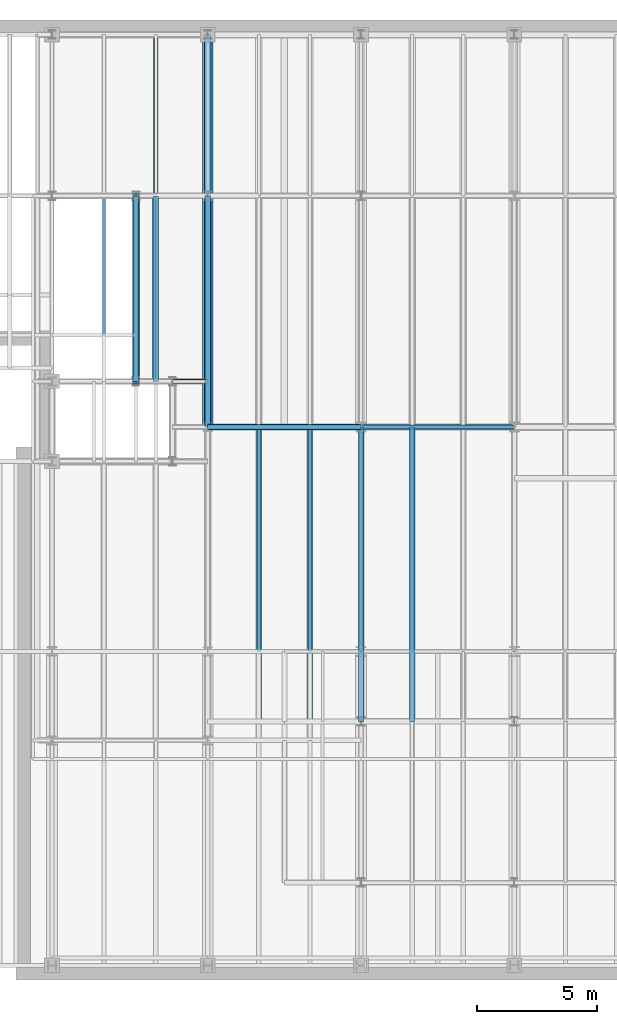
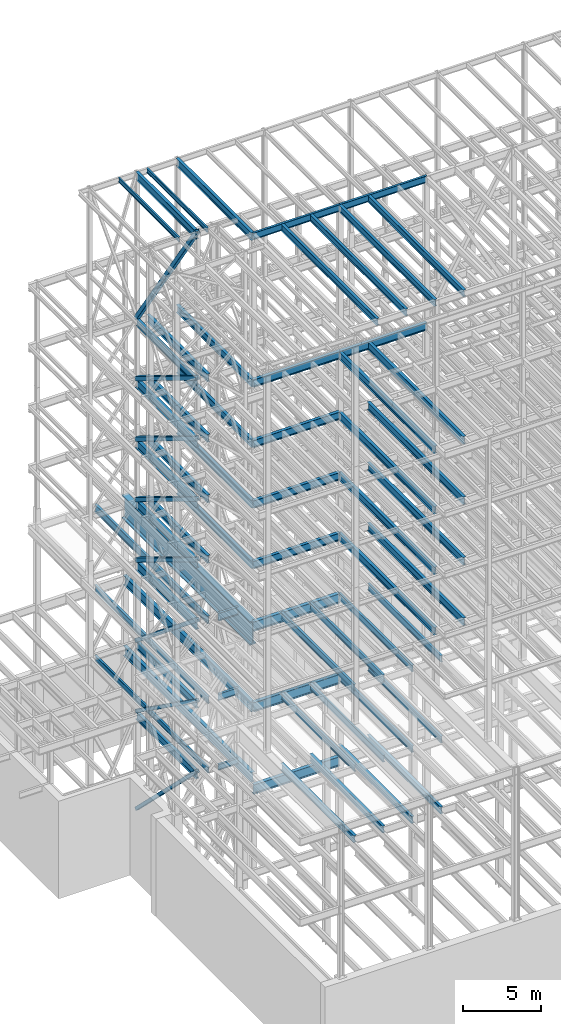
# One storey, part 127 of 150: 70 beams.
"""IFC2X3 building model written with IfcOpenShell, lengths in millimetres."""

from ifc_helpers import new_model, si_unit, frame, origin_with_axes, origin_2d_with_axis, place, context, subcontext, project, spatial, hollow_rectangle, i_section, extrude, material, type_object, element, save


model = new_model("IFC2X3")

# Units and contexts
model_context = context("Model", 3, precision=1e-05, world=origin_with_axes())
body_context = subcontext(model_context, "Body", "Model", "MODEL_VIEW")
ifc_project = project(units=[si_unit("LENGTHUNIT", "METRE", prefix="MILLI"), si_unit("AREAUNIT", "SQUARE_METRE"), si_unit("VOLUMEUNIT", "CUBIC_METRE"), si_unit("MASSUNIT", "GRAM", prefix="KILO"), si_unit("TIMEUNIT", "SECOND"), si_unit("PLANEANGLEUNIT", "RADIAN"), si_unit("SOLIDANGLEUNIT", "STERADIAN"), si_unit("THERMODYNAMICTEMPERATUREUNIT", "DEGREE_CELSIUS"), si_unit("LUMINOUSINTENSITYUNIT", "LUMEN")], contexts=[model_context])

# Site, building, storey
site_placement = place(None, origin_with_axes())
site = spatial("IfcSite", under=ifc_project, at=site_placement, CompositionType="ELEMENT")
building_placement = place(site_placement, origin_with_axes())
building = spatial("IfcBuilding", under=site, at=building_placement, Name="Undefined", CompositionType="ELEMENT")
storey_placement = place(building_placement, origin_with_axes())
storey = spatial("IfcBuildingStorey", under=building, at=storey_placement, Name="Undefined", CompositionType="ELEMENT", Elevation=0.0)

# Beams
ifc_material_1 = material(Name="STEEL/A992")
beam_type_1 = type_object("IfcBeamType", Name="W18X35", PredefinedType="NOTDEFINED")
beam_1_placement = place(storey_placement, frame((10312.39949708, 24384.0, 23548.975), z_axis=(0.0, 0.0, 1.0), x_axis=(1.0, 0.0, 0.0)))
element("IfcBeam", 1, at=beam_1_placement, inside=storey, type_object=beam_type_1, material=ifc_material_1, Name="BEAM", ObjectType="W18X35", context=body_context, shape_type="SweptSolid", body=[
    extrude(i_section(OverallWidth=152.4, OverallDepth=450.85, WebThickness=7.9375, FlangeThickness=10.795, FilletRadius=17.78, at=origin_2d_with_axis()), frame((1473.20050292, 0.0, 0.0), z_axis=(-1.0, 0.0, 0.0), x_axis=(0.0, -1.0, 0.0)), (0.0, 0.0, 1.0), 1473.20050292),
])
beam_2_placement = place(storey_placement, frame((9618.13333333333, 24384.0, 23548.975), z_axis=(0.0, 0.0, 1.0), x_axis=(0.0, 1.0, 0.0)))
element("IfcBeam", 2, at=beam_2_placement, inside=storey, type_object=beam_type_1, material=ifc_material_1, Name="BEAM", ObjectType="W18X35", context=body_context, shape_type="SweptSolid", body=[
    extrude(i_section(OverallWidth=152.4, OverallDepth=450.85, WebThickness=7.9375, FlangeThickness=10.795, FilletRadius=17.78, at=origin_2d_with_axis()), frame((14478.0, 0.0, 0.0), z_axis=(-1.0, 0.0, 0.0), x_axis=(0.0, -1.0, 0.0)), (0.0, 0.0, 1.0), 14478.0),
])
beam_type_2 = type_object("IfcBeamType", PredefinedType="NOTDEFINED")
beam_3_placement = place(storey_placement, frame((11785.6, 22479.0, 34671.0), z_axis=(0.0, 0.0, 1.0), x_axis=(0.0, 1.0, 0.0)))
element("IfcBeam", 3, at=beam_3_placement, inside=storey, type_object=beam_type_2, material=ifc_material_1, Name="BEAM", context=body_context, shape_type="SweptSolid", body=[
    extrude(i_section(OverallWidth=457.2, OverallDepth=1828.8, WebThickness=44.45, FlangeThickness=88.9, FilletRadius=31.115, at=origin_2d_with_axis()), frame((16383.0, 0.0, 0.0), z_axis=(-1.0, 0.0, 0.0), x_axis=(0.0, -1.0, 0.0)), (0.0, 0.0, 1.0), 16383.0),
])
ifc_material_2 = material()
beam_type_3 = type_object("IfcBeamType", Name="HSS12X12X5/8", PredefinedType="NOTDEFINED")
beam_4_placement = place(storey_placement, frame((8788.39896651299, 32131.0000000001, 29286.2), z_axis=(0.0, 0.630879840272755, 0.775880549529), x_axis=(0.0, -0.775880549529, 0.630879840272755)))
element("IfcBeam", 4, at=beam_4_placement, inside=storey, type_object=beam_type_3, material=ifc_material_2, Name="BEAM", ObjectType="HSS12X12X5/8", context=body_context, shape_type="SweptSolid", body=[
    extrude(hollow_rectangle(XDim=304.8, YDim=304.8, WallThickness=15.875, InnerFilletRadius=15.875, OuterFilletRadius=31.75, at=origin_2d_with_axis()), frame((9984.78490704744, 0.0, 8.9387583291435e-12), z_axis=(-1.0, 0.0, 0.0), x_axis=(0.0, -1.0, 0.0)), (0.0, 0.0, 1.0), 9984.78490704744),
])
beam_type_4 = type_object("IfcBeamType", Name="HSS12X12X3/8", PredefinedType="NOTDEFINED")
beam_5_placement = place(storey_placement, frame((8788.39896651299, 32131.0000000001, 54483.0), z_axis=(0.0, 0.827780944763595, 0.56105143033976), x_axis=(0.0, -0.561051430339763, 0.827780944763593)))
element("IfcBeam", 5, at=beam_5_placement, inside=storey, type_object=beam_type_4, material=ifc_material_2, Name="BEAM", ObjectType="HSS12X12X3/8", context=body_context, shape_type="SweptSolid", body=[
    extrude(hollow_rectangle(XDim=304.8, YDim=304.8, WallThickness=9.525, InnerFilletRadius=9.5249, OuterFilletRadius=19.0499, at=origin_2d_with_axis()), frame((13808.0014948042, 0.0, 0.0), z_axis=(-1.0, 0.0, 0.0), x_axis=(0.0, -1.0, 0.0)), (0.0, 0.0, 1.0), 13808.0014948042),
])
for number, where, z_axis, x_axis, name in (
    (6, (8788.39896651299, 32131.0000000001, 40309.8), (0.0, 0.520657137219164, 0.853765861031434), (0.0, -0.853765861031433, 0.520657137219164), "BEAM"),
    (7, (8788.39896651299, 32131.0000000001, 35585.4), (0.0, 0.520657137219164, 0.853765861031434), (0.0, -0.853765861031433, 0.520657137219164), "BEAM"),
):
    element("IfcBeam", number, at=place(storey_placement, frame(where, z_axis=z_axis, x_axis=x_axis)), inside=storey, type_object=beam_type_4, material=ifc_material_2, Name=name, ObjectType="HSS12X12X3/8", context=body_context, shape_type="SweptSolid", body=[
        extrude(hollow_rectangle(XDim=304.8, YDim=304.8, WallThickness=9.525, InnerFilletRadius=9.5249, OuterFilletRadius=19.0499, at=origin_2d_with_axis()), frame((9073.91670448887, 0.0, 0.0), z_axis=(-1.0, 0.0, 0.0), x_axis=(0.0, -1.0, 0.0)), (0.0, 0.0, 1.0), 9073.91670448887),
    ])
beam_type_5 = type_object("IfcBeamType", Name="HSS10X10X1/2", PredefinedType="NOTDEFINED")
beam_6_placement = place(storey_placement, frame((8788.39896651299, 32131.0000000001, 23774.4), z_axis=(0.0, 0.579720908961089, 0.814815112595078), x_axis=(0.0, -0.814815112595078, 0.579720908961088)))
element("IfcBeam", 8, at=beam_6_placement, inside=storey, type_object=beam_type_5, material=ifc_material_2, Name="BEAM", ObjectType="HSS10X10X1/2", context=body_context, shape_type="SweptSolid", body=[
    extrude(hollow_rectangle(XDim=254.0, YDim=254.0, WallThickness=12.7, InnerFilletRadius=12.6999, OuterFilletRadius=25.3999, at=origin_2d_with_axis()), frame((9507.67838328591, 0.0, -5.27782172592745e-13), z_axis=(-1.0, 0.0, 0.0), x_axis=(0.0, -1.0, 0.0)), (0.0, 0.0, 1.0), 9507.67838328591),
])
beam_7_placement = place(storey_placement, frame((8788.39896651299, 32131.0000000001, 16154.4), z_axis=(0.0, 0.701238983615864, 0.71292628500946), x_axis=(0.0, -0.71292628500946, 0.701238983615864)))
element("IfcBeam", 9, at=beam_7_placement, inside=storey, type_object=beam_type_5, material=ifc_material_2, Name="BEAM", ObjectType="HSS10X10X1/2", context=body_context, shape_type="SweptSolid", body=[
    extrude(hollow_rectangle(XDim=254.0, YDim=254.0, WallThickness=12.7, InnerFilletRadius=12.6999, OuterFilletRadius=25.3999, at=origin_2d_with_axis()), frame((10866.4809851213, 0.0, -6.03210869316655e-13), z_axis=(-1.0, 0.0, 0.0), x_axis=(0.0, -1.0, 0.0)), (0.0, 0.0, 1.0), 10866.4809851213),
])
beam_type_6 = type_object("IfcBeamType", Name="HSS12X12X1/4", PredefinedType="NOTDEFINED")
beam_8_placement = place(storey_placement, frame((8788.39896651299, 32131.0000000001, 49758.6), z_axis=(0.0, 0.520657137219164, 0.853765861031434), x_axis=(0.0, -0.853765861031433, 0.520657137219164)))
element("IfcBeam", 10, at=beam_8_placement, inside=storey, type_object=beam_type_6, material=ifc_material_2, Name="BEAM", ObjectType="HSS12X12X1/4", context=body_context, shape_type="SweptSolid", body=[
    extrude(hollow_rectangle(XDim=304.8, YDim=304.8, WallThickness=6.35, InnerFilletRadius=6.3499, OuterFilletRadius=12.6999, at=origin_2d_with_axis()), frame((9073.91670448887, 0.0, 0.0), z_axis=(-1.0, 0.0, 0.0), x_axis=(0.0, -1.0, 0.0)), (0.0, 0.0, 1.0), 9073.91670448887),
])
beam_type_7 = type_object("IfcBeamType", Name="HSS12X12X5/16", PredefinedType="NOTDEFINED")
beam_9_placement = place(storey_placement, frame((8788.39896651299, 32131.0000000001, 45034.2), z_axis=(0.0, 0.520657137219164, 0.853765861031434), x_axis=(0.0, -0.853765861031433, 0.520657137219164)))
element("IfcBeam", 11, at=beam_9_placement, inside=storey, type_object=beam_type_7, material=ifc_material_2, Name="BEAM", ObjectType="HSS12X12X5/16", context=body_context, shape_type="SweptSolid", body=[
    extrude(hollow_rectangle(XDim=304.8, YDim=304.8, WallThickness=7.9375, InnerFilletRadius=7.9375, OuterFilletRadius=15.875, at=origin_2d_with_axis()), frame((9073.91670448887, 0.0, 0.0), z_axis=(-1.0, 0.0, 0.0), x_axis=(0.0, -1.0, 0.0)), (0.0, 0.0, 1.0), 9073.91670448888),
])
beam_type_8 = type_object("IfcBeamType", Name="W21X50", PredefinedType="NOTDEFINED")
for number, where, z_axis, x_axis, name in (
    (12, (18186.4, 22479.0, 65647.8875), (0.0, 0.0, 1.0), (1.0, 0.0, 0.0), "BEAM"),
    (13, (11785.6, 22479.0, 65647.8875), (0.0, 0.0, 1.0), (1.0, 0.0, 0.0), "BEAM"),
):
    element("IfcBeam", number, at=place(storey_placement, frame(where, z_axis=z_axis, x_axis=x_axis)), inside=storey, type_object=beam_type_8, material=ifc_material_1, Name=name, ObjectType="W21X50", context=body_context, shape_type="SweptSolid", body=[
        extrude(i_section(OverallWidth=165.862, OverallDepth=530.225, WebThickness=9.5249, FlangeThickness=13.589, FilletRadius=18.1609, at=origin_2d_with_axis()), frame((6400.80000000001, 0.0, 0.0), z_axis=(-1.0, 0.0, 0.0), x_axis=(0.0, -1.0, 0.0)), (0.0, 0.0, 1.0), 6400.8),
    ])
beam_type_9 = type_object("IfcBeamType", Name="W24X68", PredefinedType="NOTDEFINED")
beam_10_placement = place(storey_placement, frame((11785.6, 22479.0, 65611.375), z_axis=(0.0, 0.0, 1.0), x_axis=(0.0, 1.0, 0.0)))
element("IfcBeam", 14, at=beam_10_placement, inside=storey, type_object=beam_type_9, material=ifc_material_1, Name="BEAM", ObjectType="W24X68", context=body_context, shape_type="SweptSolid", body=[
    extrude(i_section(OverallWidth=227.838, OverallDepth=603.25, WebThickness=11.1125, FlangeThickness=14.859, FilletRadius=23.2409, at=origin_2d_with_axis()), frame((9652.0, 0.0, 0.0), z_axis=(-1.0, 0.0, 0.0), x_axis=(0.0, -1.0, 0.0)), (0.0, 0.0, 1.0), 9652.0),
])
beam_11_placement = place(storey_placement, frame((18186.4, 22479.0, 54181.375), z_axis=(0.0, 0.0, 1.0), x_axis=(1.0, 0.0, 0.0)))
element("IfcBeam", 15, at=beam_11_placement, inside=storey, type_object=beam_type_9, material=ifc_material_1, Name="BEAM", ObjectType="W24X68", context=body_context, shape_type="SweptSolid", body=[
    extrude(i_section(OverallWidth=227.838, OverallDepth=603.25, WebThickness=11.1125, FlangeThickness=14.859, FilletRadius=23.2409, at=origin_2d_with_axis()), frame((6400.80000000001, 0.0, 0.0), z_axis=(-1.0, 0.0, 0.0), x_axis=(0.0, -1.0, 0.0)), (0.0, 0.0, 1.0), 6400.8),
])
beam_12_placement = place(storey_placement, frame((11785.6, 22479.0, 54181.375), z_axis=(0.0, 0.0, 1.0), x_axis=(0.0, 1.0, 0.0)))
element("IfcBeam", 16, at=beam_12_placement, inside=storey, type_object=beam_type_9, material=ifc_material_1, Name="BEAM", ObjectType="W24X68", context=body_context, shape_type="SweptSolid", body=[
    extrude(i_section(OverallWidth=227.838, OverallDepth=603.25, WebThickness=11.1125, FlangeThickness=14.859, FilletRadius=23.2409, at=origin_2d_with_axis()), frame((9652.0, 0.0, 0.0), z_axis=(-1.0, 0.0, 0.0), x_axis=(0.0, -1.0, 0.0)), (0.0, 0.0, 1.0), 9652.0),
])
beam_13_placement = place(storey_placement, frame((9618.13333333333, 24384.0, 54181.375), z_axis=(0.0, 0.0, 1.0), x_axis=(0.0, 1.0, 0.0)))
element("IfcBeam", 17, at=beam_13_placement, inside=storey, type_object=beam_type_9, material=ifc_material_1, Name="BEAM", ObjectType="W24X68", context=body_context, shape_type="SweptSolid", body=[
    extrude(i_section(OverallWidth=227.838, OverallDepth=603.25, WebThickness=11.1125, FlangeThickness=14.859, FilletRadius=23.2409, at=origin_2d_with_axis()), frame((7747.0, 0.0, 0.0), z_axis=(-1.0, 0.0, 0.0), x_axis=(0.0, -1.0, 0.0)), (0.0, 0.0, 1.0), 7747.0),
])
beam_14_placement = place(storey_placement, frame((11785.6, 22479.0, 54181.375), z_axis=(0.0, 0.0, 1.0), x_axis=(1.0, 0.0, 0.0)))
element("IfcBeam", 18, at=beam_14_placement, inside=storey, type_object=beam_type_9, material=ifc_material_1, Name="BEAM", ObjectType="W24X68", context=body_context, shape_type="SweptSolid", body=[
    extrude(i_section(OverallWidth=227.838, OverallDepth=603.25, WebThickness=11.1125, FlangeThickness=14.859, FilletRadius=23.2409, at=origin_2d_with_axis()), frame((6400.80000000001, 0.0, 0.0), z_axis=(-1.0, 0.0, 0.0), x_axis=(0.0, -1.0, 0.0)), (0.0, 0.0, 1.0), 6400.8),
])
for number, where, z_axis, x_axis, name in (
    (19, (20320.0, 10185.4, 54181.375), (0.0, 0.0, 1.0), (0.0, 1.0, 0.0), "BEAM"),
    (20, (18186.4, 10185.4, 54181.375), (0.0, 0.0, 1.0), (0.0, 1.0, 0.0), "BEAM"),
):
    element("IfcBeam", number, at=place(storey_placement, frame(where, z_axis=z_axis, x_axis=x_axis)), inside=storey, type_object=beam_type_9, material=ifc_material_1, Name=name, ObjectType="W24X68", context=body_context, shape_type="SweptSolid", body=[
        extrude(i_section(OverallWidth=227.838, OverallDepth=603.25, WebThickness=11.1125, FlangeThickness=14.859, FilletRadius=23.2409, at=origin_2d_with_axis()), frame((12293.6, 0.0, 0.0), z_axis=(-1.0, 0.0, 0.0), x_axis=(0.0, -1.0, 0.0)), (0.0, 0.0, 1.0), 12293.6),
    ])
beam_15_placement = place(storey_placement, frame((11785.6, 22479.0, 49456.975), z_axis=(0.0, 0.0, 1.0), x_axis=(0.0, 1.0, 0.0)))
element("IfcBeam", 21, at=beam_15_placement, inside=storey, type_object=beam_type_9, material=ifc_material_1, Name="BEAM", ObjectType="W24X68", context=body_context, shape_type="SweptSolid", body=[
    extrude(i_section(OverallWidth=227.838, OverallDepth=603.25, WebThickness=11.1125, FlangeThickness=14.859, FilletRadius=23.2409, at=origin_2d_with_axis()), frame((9652.0, 0.0, 0.0), z_axis=(-1.0, 0.0, 0.0), x_axis=(0.0, -1.0, 0.0)), (0.0, 0.0, 1.0), 9652.0),
])
beam_16_placement = place(storey_placement, frame((9618.13333333333, 24384.0, 49456.975), z_axis=(0.0, 0.0, 1.0), x_axis=(0.0, 1.0, 0.0)))
element("IfcBeam", 22, at=beam_16_placement, inside=storey, type_object=beam_type_9, material=ifc_material_1, Name="BEAM", ObjectType="W24X68", context=body_context, shape_type="SweptSolid", body=[
    extrude(i_section(OverallWidth=227.838, OverallDepth=603.25, WebThickness=11.1125, FlangeThickness=14.859, FilletRadius=23.2409, at=origin_2d_with_axis()), frame((7747.0, 0.0, 0.0), z_axis=(-1.0, 0.0, 0.0), x_axis=(0.0, -1.0, 0.0)), (0.0, 0.0, 1.0), 7747.0),
])
beam_17_placement = place(storey_placement, frame((11785.6, 22479.0, 49456.975), z_axis=(0.0, 0.0, 1.0), x_axis=(1.0, 0.0, 0.0)))
element("IfcBeam", 23, at=beam_17_placement, inside=storey, type_object=beam_type_9, material=ifc_material_1, Name="BEAM", ObjectType="W24X68", context=body_context, shape_type="SweptSolid", body=[
    extrude(i_section(OverallWidth=227.838, OverallDepth=603.25, WebThickness=11.1125, FlangeThickness=14.859, FilletRadius=23.2409, at=origin_2d_with_axis()), frame((6400.80000000001, 0.0, 0.0), z_axis=(-1.0, 0.0, 0.0), x_axis=(0.0, -1.0, 0.0)), (0.0, 0.0, 1.0), 6400.8),
])
for number, where, z_axis, x_axis, name in (
    (24, (20320.0, 10185.4, 49456.975), (0.0, 0.0, 1.0), (0.0, 1.0, 0.0), "BEAM"),
    (25, (18186.4, 10185.4, 49456.975), (0.0, 0.0, 1.0), (0.0, 1.0, 0.0), "BEAM"),
):
    element("IfcBeam", number, at=place(storey_placement, frame(where, z_axis=z_axis, x_axis=x_axis)), inside=storey, type_object=beam_type_9, material=ifc_material_1, Name=name, ObjectType="W24X68", context=body_context, shape_type="SweptSolid", body=[
        extrude(i_section(OverallWidth=227.838, OverallDepth=603.25, WebThickness=11.1125, FlangeThickness=14.859, FilletRadius=23.2409, at=origin_2d_with_axis()), frame((12293.6, 0.0, 0.0), z_axis=(-1.0, 0.0, 0.0), x_axis=(0.0, -1.0, 0.0)), (0.0, 0.0, 1.0), 12293.6),
    ])
beam_18_placement = place(storey_placement, frame((11785.6, 22479.0, 44732.575), z_axis=(0.0, 0.0, 1.0), x_axis=(0.0, 1.0, 0.0)))
element("IfcBeam", 26, at=beam_18_placement, inside=storey, type_object=beam_type_9, material=ifc_material_1, Name="BEAM", ObjectType="W24X68", context=body_context, shape_type="SweptSolid", body=[
    extrude(i_section(OverallWidth=227.838, OverallDepth=603.25, WebThickness=11.1125, FlangeThickness=14.859, FilletRadius=23.2409, at=origin_2d_with_axis()), frame((9652.0, 0.0, 0.0), z_axis=(-1.0, 0.0, 0.0), x_axis=(0.0, -1.0, 0.0)), (0.0, 0.0, 1.0), 9652.0),
])
beam_19_placement = place(storey_placement, frame((9618.13333333333, 24384.0, 44732.575), z_axis=(0.0, 0.0, 1.0), x_axis=(0.0, 1.0, 0.0)))
element("IfcBeam", 27, at=beam_19_placement, inside=storey, type_object=beam_type_9, material=ifc_material_1, Name="BEAM", ObjectType="W24X68", context=body_context, shape_type="SweptSolid", body=[
    extrude(i_section(OverallWidth=227.838, OverallDepth=603.25, WebThickness=11.1125, FlangeThickness=14.859, FilletRadius=23.2409, at=origin_2d_with_axis()), frame((7747.0, 0.0, 0.0), z_axis=(-1.0, 0.0, 0.0), x_axis=(0.0, -1.0, 0.0)), (0.0, 0.0, 1.0), 7747.0),
])
beam_20_placement = place(storey_placement, frame((11785.6, 22479.0, 44732.575), z_axis=(0.0, 0.0, 1.0), x_axis=(1.0, 0.0, 0.0)))
element("IfcBeam", 28, at=beam_20_placement, inside=storey, type_object=beam_type_9, material=ifc_material_1, Name="BEAM", ObjectType="W24X68", context=body_context, shape_type="SweptSolid", body=[
    extrude(i_section(OverallWidth=227.838, OverallDepth=603.25, WebThickness=11.1125, FlangeThickness=14.859, FilletRadius=23.2409, at=origin_2d_with_axis()), frame((6400.80000000001, 0.0, 0.0), z_axis=(-1.0, 0.0, 0.0), x_axis=(0.0, -1.0, 0.0)), (0.0, 0.0, 1.0), 6400.8),
])
for number, where, z_axis, x_axis, name in (
    (29, (20320.0, 10185.4, 44732.575), (0.0, 0.0, 1.0), (0.0, 1.0, 0.0), "BEAM"),
    (30, (18186.4, 10185.4, 44732.575), (0.0, 0.0, 1.0), (0.0, 1.0, 0.0), "BEAM"),
):
    element("IfcBeam", number, at=place(storey_placement, frame(where, z_axis=z_axis, x_axis=x_axis)), inside=storey, type_object=beam_type_9, material=ifc_material_1, Name=name, ObjectType="W24X68", context=body_context, shape_type="SweptSolid", body=[
        extrude(i_section(OverallWidth=227.838, OverallDepth=603.25, WebThickness=11.1125, FlangeThickness=14.859, FilletRadius=23.2409, at=origin_2d_with_axis()), frame((12293.6, 0.0, 0.0), z_axis=(-1.0, 0.0, 0.0), x_axis=(0.0, -1.0, 0.0)), (0.0, 0.0, 1.0), 12293.6),
    ])
beam_21_placement = place(storey_placement, frame((11785.6, 22479.0, 40008.175), z_axis=(0.0, 0.0, 1.0), x_axis=(0.0, 1.0, 0.0)))
element("IfcBeam", 31, at=beam_21_placement, inside=storey, type_object=beam_type_9, material=ifc_material_1, Name="BEAM", ObjectType="W24X68", context=body_context, shape_type="SweptSolid", body=[
    extrude(i_section(OverallWidth=227.838, OverallDepth=603.25, WebThickness=11.1125, FlangeThickness=14.859, FilletRadius=23.2409, at=origin_2d_with_axis()), frame((9652.0, 0.0, 0.0), z_axis=(-1.0, 0.0, 0.0), x_axis=(0.0, -1.0, 0.0)), (0.0, 0.0, 1.0), 9652.0),
])
beam_22_placement = place(storey_placement, frame((9618.13333333333, 24384.0, 40008.175), z_axis=(0.0, 0.0, 1.0), x_axis=(0.0, 1.0, 0.0)))
element("IfcBeam", 32, at=beam_22_placement, inside=storey, type_object=beam_type_9, material=ifc_material_1, Name="BEAM", ObjectType="W24X68", context=body_context, shape_type="SweptSolid", body=[
    extrude(i_section(OverallWidth=227.838, OverallDepth=603.25, WebThickness=11.1125, FlangeThickness=14.859, FilletRadius=23.2409, at=origin_2d_with_axis()), frame((7747.0, 0.0, 0.0), z_axis=(-1.0, 0.0, 0.0), x_axis=(0.0, -1.0, 0.0)), (0.0, 0.0, 1.0), 7747.0),
])
beam_23_placement = place(storey_placement, frame((11785.6, 22479.0, 40008.175), z_axis=(0.0, 0.0, 1.0), x_axis=(1.0, 0.0, 0.0)))
element("IfcBeam", 33, at=beam_23_placement, inside=storey, type_object=beam_type_9, material=ifc_material_1, Name="BEAM", ObjectType="W24X68", context=body_context, shape_type="SweptSolid", body=[
    extrude(i_section(OverallWidth=227.838, OverallDepth=603.25, WebThickness=11.1125, FlangeThickness=14.859, FilletRadius=23.2409, at=origin_2d_with_axis()), frame((6400.80000000001, 0.0, 0.0), z_axis=(-1.0, 0.0, 0.0), x_axis=(0.0, -1.0, 0.0)), (0.0, 0.0, 1.0), 6400.8),
])
for number, where, z_axis, x_axis, name in (
    (34, (20320.0, 10185.4, 40008.175), (0.0, 0.0, 1.0), (0.0, 1.0, 0.0), "BEAM"),
    (35, (18186.4, 10185.4, 40008.175), (0.0, 0.0, 1.0), (0.0, 1.0, 0.0), "BEAM"),
):
    element("IfcBeam", number, at=place(storey_placement, frame(where, z_axis=z_axis, x_axis=x_axis)), inside=storey, type_object=beam_type_9, material=ifc_material_1, Name=name, ObjectType="W24X68", context=body_context, shape_type="SweptSolid", body=[
        extrude(i_section(OverallWidth=227.838, OverallDepth=603.25, WebThickness=11.1125, FlangeThickness=14.859, FilletRadius=23.2409, at=origin_2d_with_axis()), frame((12293.6, 0.0, 0.0), z_axis=(-1.0, 0.0, 0.0), x_axis=(0.0, -1.0, 0.0)), (0.0, 0.0, 1.0), 12293.6),
    ])
beam_24_placement = place(storey_placement, frame((8788.39949708, 24384.0, 28984.575), z_axis=(0.0, 0.0, 1.0), x_axis=(0.0, 1.0, 0.0)))
element("IfcBeam", 36, at=beam_24_placement, inside=storey, type_object=beam_type_9, material=ifc_material_1, Name="BEAM", ObjectType="W24X68", context=body_context, shape_type="SweptSolid", body=[
    extrude(i_section(OverallWidth=227.838, OverallDepth=603.25, WebThickness=11.1125, FlangeThickness=14.859, FilletRadius=23.2409, at=origin_2d_with_axis()), frame((7746.99929895383, 0.0, 0.0), z_axis=(-1.0, 0.0, 0.0), x_axis=(0.0, -1.0, 0.0)), (0.0, 0.0, 1.0), 7746.99929895383),
])
beam_type_10 = type_object("IfcBeamType", Name="W14X22", PredefinedType="NOTDEFINED")
for number, where, z_axis, x_axis, name in (
    (37, (9550.39949708, 24384.0, 65738.375), (0.0, 0.0, 1.0), (0.0, 1.0, 0.0), "BEAM"),
    (38, (7450.66666666667, 24384.0, 65738.375), (0.0, 0.0, 1.0), (0.0, 1.0, 0.0), "BEAM"),
):
    element("IfcBeam", number, at=place(storey_placement, frame(where, z_axis=z_axis, x_axis=x_axis)), inside=storey, type_object=beam_type_10, material=ifc_material_1, Name=name, ObjectType="W14X22", context=body_context, shape_type="SweptSolid", body=[
        extrude(i_section(OverallWidth=127.0, OverallDepth=349.25, WebThickness=6.3499, FlangeThickness=8.509, FilletRadius=18.4785, at=origin_2d_with_axis()), frame((7746.99845060008, 0.0, 0.0), z_axis=(-1.0, 0.0, 0.0), x_axis=(0.0, -1.0, 0.0)), (0.0, 0.0, 1.0), 7746.99845060008),
    ])
beam_type_11 = type_object("IfcBeamType", Name="W21X55", PredefinedType="NOTDEFINED")
for number, where, z_axis, x_axis, name in (
    (39, (16052.8, 10185.4, 65649.475), (0.0, 0.0, 1.0), (0.0, 1.0, 0.0), "BEAM"),
    (40, (13919.2, 10185.4, 65649.475), (0.0, 0.0, 1.0), (0.0, 1.0, 0.0), "BEAM"),
    (41, (20320.0, 10185.4, 65649.475), (0.0, 0.0, 1.0), (0.0, 1.0, 0.0), "BEAM"),
    (42, (18186.4, 10185.4, 65649.475), (0.0, 0.0, 1.0), (0.0, 1.0, 0.0), "BEAM"),
):
    element("IfcBeam", number, at=place(storey_placement, frame(where, z_axis=z_axis, x_axis=x_axis)), inside=storey, type_object=beam_type_11, material=ifc_material_1, Name=name, ObjectType="W21X55", context=body_context, shape_type="SweptSolid", body=[
        extrude(i_section(OverallWidth=208.788, OverallDepth=527.05, WebThickness=9.5, FlangeThickness=13.2588, FilletRadius=16.8624, at=origin_2d_with_axis()), frame((12293.6, 0.0, 0.0), z_axis=(-1.0, 0.0, 0.0), x_axis=(0.0, -1.0, 0.0)), (0.0, 0.0, 1.0), 12293.6),
    ])
beam_type_12 = type_object("IfcBeamType", Name="W27X84", PredefinedType="NOTDEFINED")
for number, where, z_axis, x_axis, name in (
    (43, (8788.39949708, 24384.0, 49418.875), (0.0, 0.0, 1.0), (0.0, 1.0, 0.0), "BEAM"),
    (44, (8788.39949708, 24384.0, 44694.475), (0.0, 0.0, 1.0), (0.0, 1.0, 0.0), "BEAM"),
    (45, (8788.39949708, 24384.0, 39970.075), (0.0, 0.0, 1.0), (0.0, 1.0, 0.0), "BEAM"),
):
    element("IfcBeam", number, at=place(storey_placement, frame(where, z_axis=z_axis, x_axis=x_axis)), inside=storey, type_object=beam_type_12, material=ifc_material_1, Name=name, ObjectType="W27X84", context=body_context, shape_type="SweptSolid", body=[
        extrude(i_section(OverallWidth=254.0, OverallDepth=679.45, WebThickness=11.1125, FlangeThickness=16.256, FilletRadius=23.4314, at=origin_2d_with_axis()), frame((7747.0, 0.0, 0.0), z_axis=(-1.0, 0.0, 0.0), x_axis=(0.0, -1.0, 0.0)), (0.0, 0.0, 1.0), 7747.0),
    ])
beam_type_13 = type_object("IfcBeamType", Name="W24X76", PredefinedType="NOTDEFINED")
beam_25_placement = place(storey_placement, frame((8788.39949708, 24384.0, 65609.7875), z_axis=(0.0, 0.0, 1.0), x_axis=(0.0, 1.0, 0.0)))
element("IfcBeam", 46, at=beam_25_placement, inside=storey, type_object=beam_type_13, material=ifc_material_1, Name="BEAM", ObjectType="W24X76", context=body_context, shape_type="SweptSolid", body=[
    extrude(i_section(OverallWidth=228.346, OverallDepth=606.425, WebThickness=11.1125, FlangeThickness=17.272, FilletRadius=22.4155, at=origin_2d_with_axis()), frame((7746.99929895383, 0.0, 0.0), z_axis=(-1.0, 0.0, 0.0), x_axis=(0.0, -1.0, 0.0)), (0.0, 0.0, 1.0), 7746.99929895383),
])
beam_26_placement = place(storey_placement, frame((8788.39949708, 24384.0, 23471.1875), z_axis=(0.0, 0.0, 1.0), x_axis=(0.0, 1.0, 0.0)))
element("IfcBeam", 47, at=beam_26_placement, inside=storey, type_object=beam_type_13, material=ifc_material_1, Name="BEAM", ObjectType="W24X76", context=body_context, shape_type="SweptSolid", body=[
    extrude(i_section(OverallWidth=228.346, OverallDepth=606.425, WebThickness=11.1125, FlangeThickness=17.272, FilletRadius=22.4155, at=origin_2d_with_axis()), frame((7746.9992253, 0.0, 0.0), z_axis=(-1.0, 0.0, 0.0), x_axis=(0.0, -1.0, 0.0)), (0.0, 0.0, 1.0), 7746.9992253),
])
beam_type_14 = type_object("IfcBeamType", Name="W24X55", PredefinedType="NOTDEFINED")
beam_27_placement = place(storey_placement, frame((8788.39949708, 24384.0, 54182.9625), z_axis=(0.0, 0.0, 1.0), x_axis=(0.0, 1.0, 0.0)))
element("IfcBeam", 48, at=beam_27_placement, inside=storey, type_object=beam_type_14, material=ifc_material_1, Name="BEAM", ObjectType="W24X55", context=body_context, shape_type="SweptSolid", body=[
    extrude(i_section(OverallWidth=178.054, OverallDepth=600.075, WebThickness=9.5249, FlangeThickness=12.827, FilletRadius=23.6854, at=origin_2d_with_axis()), frame((7747.0, 0.0, 0.0), z_axis=(-1.0, 0.0, 0.0), x_axis=(0.0, -1.0, 0.0)), (0.0, 0.0, 1.0), 7747.0),
])
beam_type_15 = type_object("IfcBeamType", Name="W21X44", PredefinedType="NOTDEFINED")
for number, where, z_axis, x_axis, name in (
    (49, (13919.2, 13106.4, 35323.4625), (0.0, 0.0, 1.0), (0.0, 1.0, 0.0), "BEAM"),
    (50, (16052.8, 13106.4, 35323.4625), (0.0, 0.0, 1.0), (0.0, 1.0, 0.0), "BEAM"),
    (51, (18186.4, 13106.4, 35323.4625), (0.0, 0.0, 1.0), (0.0, 1.0, 0.0), "BEAM"),
    (52, (20320.0, 13106.4, 35323.4625), (0.0, 0.0, 1.0), (0.0, 1.0, 0.0), "BEAM"),
):
    element("IfcBeam", number, at=place(storey_placement, frame(where, z_axis=z_axis, x_axis=x_axis)), inside=storey, type_object=beam_type_15, material=ifc_material_1, Name=name, ObjectType="W21X44", context=body_context, shape_type="SweptSolid", body=[
        extrude(i_section(OverallWidth=165.1, OverallDepth=523.875, WebThickness=9.5249, FlangeThickness=11.43, FilletRadius=17.145, at=origin_2d_with_axis()), frame((9372.6, 0.0, 0.0), z_axis=(-1.0, 0.0, 0.0), x_axis=(0.0, -1.0, 0.0)), (0.0, 0.0, 1.0), 9372.6),
    ])
beam_28_placement = place(storey_placement, frame((9618.13289984, 24384.0, 29024.2625), z_axis=(0.0, 0.0, 1.0), x_axis=(0.0, 1.0, 0.0)))
element("IfcBeam", 53, at=beam_28_placement, inside=storey, type_object=beam_type_15, material=ifc_material_1, Name="BEAM", ObjectType="W21X44", context=body_context, shape_type="SweptSolid", body=[
    extrude(i_section(OverallWidth=165.1, OverallDepth=523.875, WebThickness=9.5249, FlangeThickness=11.43, FilletRadius=17.145, at=origin_2d_with_axis()), frame((14478.0, 0.0, 0.0), z_axis=(-1.0, 0.0, 0.0), x_axis=(0.0, -1.0, 0.0)), (0.0, 0.0, 1.0), 14478.0),
])
beam_29_placement = place(storey_placement, frame((10312.39949708, 24384.0, 29024.2625), z_axis=(0.0, 0.0, 1.0), x_axis=(1.0, 0.0, 0.0)))
element("IfcBeam", 54, at=beam_29_placement, inside=storey, type_object=beam_type_15, material=ifc_material_1, Name="BEAM", ObjectType="W21X44", context=body_context, shape_type="SweptSolid", body=[
    extrude(i_section(OverallWidth=165.1, OverallDepth=523.875, WebThickness=9.5249, FlangeThickness=11.43, FilletRadius=17.145, at=origin_2d_with_axis()), frame((1473.20050292, 0.0, 0.0), z_axis=(-1.0, 0.0, 0.0), x_axis=(0.0, -1.0, 0.0)), (0.0, 0.0, 1.0), 1473.20050292),
])
for number, where, z_axis, x_axis, name in (
    (55, (20320.0, 13106.4, 29024.2625), (0.0, 0.0, 1.0), (0.0, 1.0, 0.0), "BEAM"),
    (56, (18186.4, 13106.4, 29024.2625), (0.0, 0.0, 1.0), (0.0, 1.0, 0.0), "BEAM"),
    (57, (16052.8, 13106.4, 29024.2625), (0.0, 0.0, 1.0), (0.0, 1.0, 0.0), "BEAM"),
    (58, (13919.2, 13106.4, 29024.2625), (0.0, 0.0, 1.0), (0.0, 1.0, 0.0), "BEAM"),
):
    element("IfcBeam", number, at=place(storey_placement, frame(where, z_axis=z_axis, x_axis=x_axis)), inside=storey, type_object=beam_type_15, material=ifc_material_1, Name=name, ObjectType="W21X44", context=body_context, shape_type="SweptSolid", body=[
        extrude(i_section(OverallWidth=165.1, OverallDepth=523.875, WebThickness=9.5249, FlangeThickness=11.43, FilletRadius=17.145, at=origin_2d_with_axis()), frame((9372.6, 0.0, 0.0), z_axis=(-1.0, 0.0, 0.0), x_axis=(0.0, -1.0, 0.0)), (0.0, 0.0, 1.0), 9372.6),
    ])
beam_type_16 = type_object("IfcBeamType", Name="W30X99", PredefinedType="NOTDEFINED")
beam_30_placement = place(storey_placement, frame((8788.39949708, 24384.0, 35209.1625), z_axis=(0.0, 0.0, 1.0), x_axis=(0.0, 1.0, 0.0)))
element("IfcBeam", 59, at=beam_30_placement, inside=storey, type_object=beam_type_16, material=ifc_material_1, Name="BEAM", ObjectType="W30X99", context=body_context, shape_type="SweptSolid", body=[
    extrude(i_section(OverallWidth=266.7, OverallDepth=752.475, WebThickness=12.6999, FlangeThickness=17.018, FilletRadius=22.6695, at=origin_2d_with_axis()), frame((7746.99929895383, 0.0, 0.0), z_axis=(-1.0, 0.0, 0.0), x_axis=(0.0, -1.0, 0.0)), (0.0, 0.0, 1.0), 7746.99929895394),
])
beam_type_17 = type_object("IfcBeamType", Name="W24X62", PredefinedType="NOTDEFINED")
beam_31_placement = place(storey_placement, frame((9618.13333333333, 24384.0, 35283.775), z_axis=(0.0, 0.0, 1.0), x_axis=(0.0, 1.0, 0.0)))
element("IfcBeam", 60, at=beam_31_placement, inside=storey, type_object=beam_type_17, material=ifc_material_1, Name="BEAM", ObjectType="W24X62", context=body_context, shape_type="SweptSolid", body=[
    extrude(i_section(OverallWidth=177.8, OverallDepth=603.25, WebThickness=11.1125, FlangeThickness=14.986, FilletRadius=23.114, at=origin_2d_with_axis()), frame((14478.0, 0.0, 0.0), z_axis=(-1.0, 0.0, 0.0), x_axis=(0.0, -1.0, 0.0)), (0.0, 0.0, 1.0), 14478.0),
])
beam_32_placement = place(storey_placement, frame((10312.39949708, 24384.0, 35283.775), z_axis=(0.0, 0.0, 1.0), x_axis=(1.0, 0.0, 0.0)))
element("IfcBeam", 61, at=beam_32_placement, inside=storey, type_object=beam_type_17, material=ifc_material_1, Name="BEAM", ObjectType="W24X62", context=body_context, shape_type="SweptSolid", body=[
    extrude(i_section(OverallWidth=177.8, OverallDepth=603.25, WebThickness=11.1125, FlangeThickness=14.986, FilletRadius=23.114, at=origin_2d_with_axis()), frame((1473.20050292, 0.0, 0.0), z_axis=(-1.0, 0.0, 0.0), x_axis=(0.0, -1.0, 0.0)), (0.0, 0.0, 1.0), 1473.20050292),
])
beam_type_18 = type_object("IfcBeamType", Name="W30X90", PredefinedType="NOTDEFINED")
beam_33_placement = place(storey_placement, frame((11785.6, 22479.0, 35210.75), z_axis=(0.0, 0.0, 1.0), x_axis=(1.0, 0.0, 0.0)))
element("IfcBeam", 62, at=beam_33_placement, inside=storey, type_object=beam_type_18, material=ifc_material_1, Name="BEAM", ObjectType="W30X90", context=body_context, shape_type="SweptSolid", body=[
    extrude(i_section(OverallWidth=264.16, OverallDepth=749.3, WebThickness=12.6999, FlangeThickness=15.494, FilletRadius=22.606, at=origin_2d_with_axis()), frame((6400.80000000001, 0.0, 0.0), z_axis=(-1.0, 0.0, 0.0), x_axis=(0.0, -1.0, 0.0)), (0.0, 0.0, 1.0), 6400.8),
])
beam_34_placement = place(storey_placement, frame((11785.6, 22479.0, 28911.55), z_axis=(0.0, 0.0, 1.0), x_axis=(0.0, 1.0, 0.0)))
element("IfcBeam", 63, at=beam_34_placement, inside=storey, type_object=beam_type_18, material=ifc_material_1, Name="BEAM", ObjectType="W30X90", context=body_context, shape_type="SweptSolid", body=[
    extrude(i_section(OverallWidth=264.16, OverallDepth=749.3, WebThickness=12.6999, FlangeThickness=15.494, FilletRadius=22.606, at=origin_2d_with_axis()), frame((16383.0, 0.0, 0.0), z_axis=(-1.0, 0.0, 0.0), x_axis=(0.0, -1.0, 0.0)), (0.0, 0.0, 1.0), 16383.0),
])
beam_35_placement = place(storey_placement, frame((11785.6, 22479.0, 28911.55), z_axis=(0.0, 0.0, 1.0), x_axis=(1.0, 0.0, 0.0)))
element("IfcBeam", 64, at=beam_35_placement, inside=storey, type_object=beam_type_18, material=ifc_material_1, Name="BEAM", ObjectType="W30X90", context=body_context, shape_type="SweptSolid", body=[
    extrude(i_section(OverallWidth=264.16, OverallDepth=749.3, WebThickness=12.6999, FlangeThickness=15.494, FilletRadius=22.606, at=origin_2d_with_axis()), frame((6400.80000000001, 0.0, 0.0), z_axis=(-1.0, 0.0, 0.0), x_axis=(0.0, -1.0, 0.0)), (0.0, 0.0, 1.0), 6400.8),
])
beam_36_placement = place(storey_placement, frame((11785.6, 22479.0, 23399.75), z_axis=(0.0, 0.0, 1.0), x_axis=(0.0, 1.0, 0.0)))
element("IfcBeam", 65, at=beam_36_placement, inside=storey, type_object=beam_type_18, material=ifc_material_1, Name="BEAM", ObjectType="W30X90", context=body_context, shape_type="SweptSolid", body=[
    extrude(i_section(OverallWidth=264.16, OverallDepth=749.3, WebThickness=12.6999, FlangeThickness=15.494, FilletRadius=22.606, at=origin_2d_with_axis()), frame((16383.0, 0.0, 0.0), z_axis=(-1.0, 0.0, 0.0), x_axis=(0.0, -1.0, 0.0)), (0.0, 0.0, 1.0), 16383.0),
])
beam_37_placement = place(storey_placement, frame((11785.6, 22479.0, 22485.35), z_axis=(0.0, 0.0, 1.0), x_axis=(1.0, 0.0, 0.0)))
element("IfcBeam", 66, at=beam_37_placement, inside=storey, type_object=beam_type_18, material=ifc_material_1, Name="BEAM", ObjectType="W30X90", context=body_context, shape_type="SweptSolid", body=[
    extrude(i_section(OverallWidth=264.16, OverallDepth=749.3, WebThickness=12.6999, FlangeThickness=15.494, FilletRadius=22.606, at=origin_2d_with_axis()), frame((6400.80000000001, 0.0, 0.0), z_axis=(-1.0, 0.0, 0.0), x_axis=(0.0, -1.0, 0.0)), (0.0, 0.0, 1.0), 6400.8),
])
beam_type_19 = type_object("IfcBeamType", Name="W21X73", PredefinedType="NOTDEFINED")
for number, where, z_axis, x_axis, name in (
    (67, (20320.0, 13106.4, 23504.525), (0.0, 0.0, 1.0), (0.0, 1.0, 0.0), "BEAM"),
    (68, (18186.4, 13106.4, 23504.525), (0.0, 0.0, 1.0), (0.0, 1.0, 0.0), "BEAM"),
    (69, (16052.8, 13106.4, 23504.525), (0.0, 0.0, 1.0), (0.0, 1.0, 0.0), "BEAM"),
    (70, (13919.2, 13106.4, 23504.525), (0.0, 0.0, 1.0), (0.0, 1.0, 0.0), "BEAM"),
):
    element("IfcBeam", number, at=place(storey_placement, frame(where, z_axis=z_axis, x_axis=x_axis)), inside=storey, type_object=beam_type_19, material=ifc_material_1, Name=name, ObjectType="W21X73", context=body_context, shape_type="SweptSolid", body=[
        extrude(i_section(OverallWidth=209.55, OverallDepth=539.75, WebThickness=11.1125, FlangeThickness=18.796, FilletRadius=17.7164, at=origin_2d_with_axis()), frame((9372.6, 0.0, 0.0), z_axis=(-1.0, 0.0, 0.0), x_axis=(0.0, -1.0, 0.0)), (0.0, 0.0, 1.0), 9372.6),
    ])

save(model, "model.ifc")
